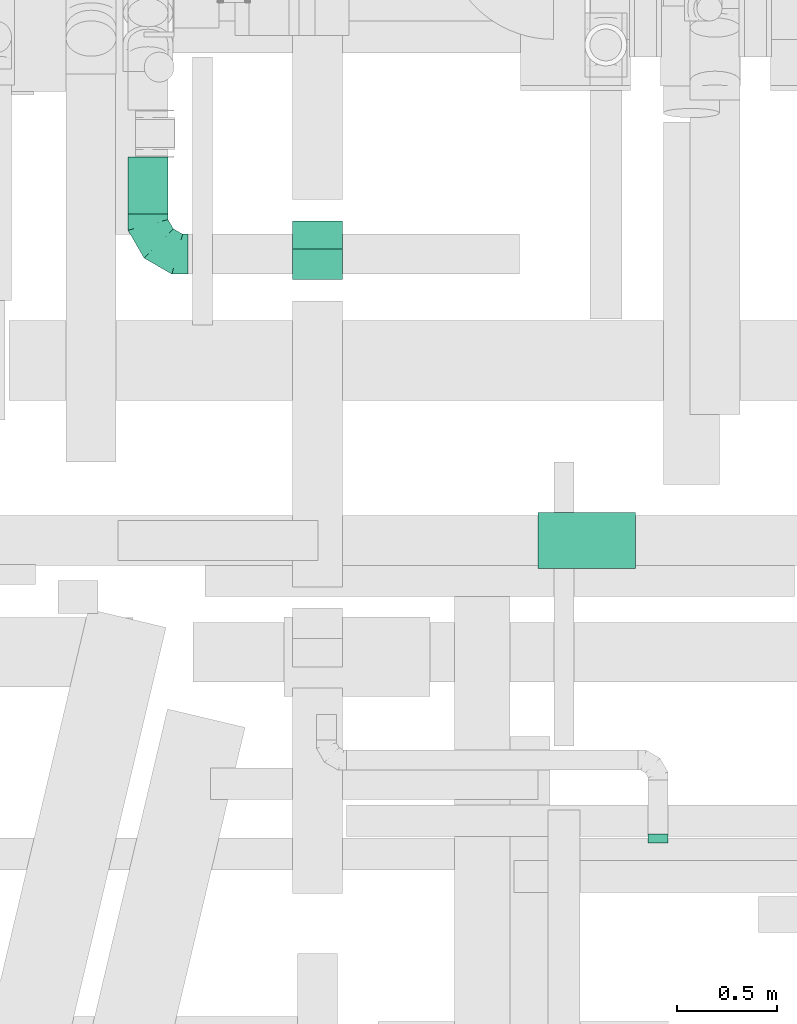
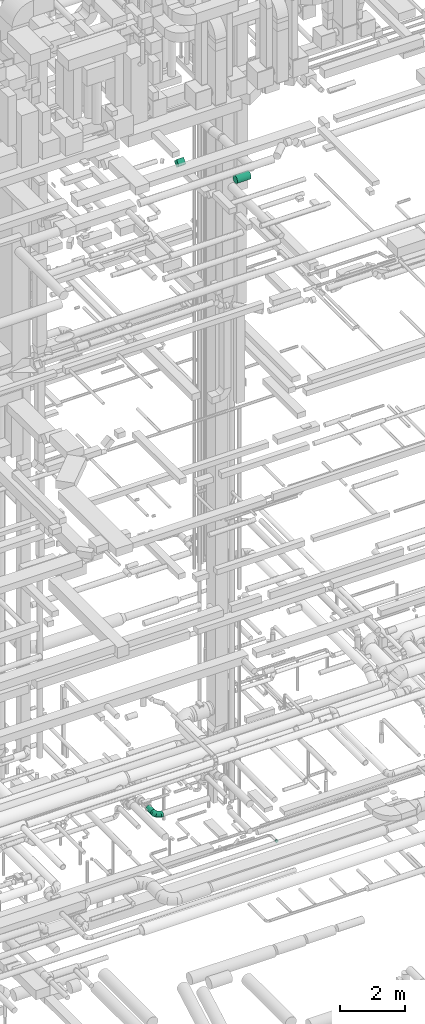
# One storey, part 208 of 337: 3 flow segments, 2 flow fittings.
"""IFC2X3 building model written with IfcOpenShell, lengths in millimetres."""

from ifc_helpers import new_model, entity, si_unit, converted_unit, derived_unit, direction, frame, origin, origin_2d_with_axis, place, context, subcontext, project, spatial, rectangle, circle, extrude, faceted_brep, source, transform, mapped, material, type_object, type_shapes, element, save


model = new_model("IFC2X3")

# Units and contexts
model_context = context("Model", 3, precision=0.01, world=origin(), true_north=direction((6.12303176911189e-17, 1.0)))
body_context = subcontext(model_context, "Body", "Model", "MODEL_VIEW")
ifc_project = project(units=[si_unit("LENGTHUNIT", "METRE", prefix="MILLI"), si_unit("AREAUNIT", "SQUARE_METRE"), si_unit("VOLUMEUNIT", "CUBIC_METRE"), converted_unit("PLANEANGLEUNIT", "DEGREE", entity("IfcRatioMeasure", 0.0174532925199433), si_unit("PLANEANGLEUNIT", "RADIAN"), dimensions=[0, 0, 0, 0, 0, 0, 0]), si_unit("MASSUNIT", "GRAM", prefix="KILO"), derived_unit("MASSDENSITYUNIT", [(si_unit("MASSUNIT", "GRAM", prefix="KILO"), 1), (si_unit("LENGTHUNIT", "METRE"), -3)]), derived_unit("MOMENTOFINERTIAUNIT", [(si_unit("LENGTHUNIT", "METRE"), 4)]), si_unit("TIMEUNIT", "SECOND"), si_unit("FREQUENCYUNIT", "HERTZ"), si_unit("THERMODYNAMICTEMPERATUREUNIT", "DEGREE_CELSIUS"), derived_unit("THERMALTRANSMITTANCEUNIT", [(si_unit("MASSUNIT", "GRAM", prefix="KILO"), 1), (si_unit("THERMODYNAMICTEMPERATUREUNIT", "KELVIN"), -1), (si_unit("TIMEUNIT", "SECOND"), -3)]), derived_unit("VOLUMETRICFLOWRATEUNIT", [(si_unit("LENGTHUNIT", "METRE"), 3), (si_unit("TIMEUNIT", "SECOND"), -1)]), derived_unit("MASSFLOWRATEUNIT", [(si_unit("MASSUNIT", "GRAM", prefix="KILO"), 1), (si_unit("TIMEUNIT", "SECOND"), -1)]), derived_unit("ROTATIONALFREQUENCYUNIT", [(si_unit("TIMEUNIT", "SECOND"), -1)]), si_unit("ELECTRICCURRENTUNIT", "AMPERE"), si_unit("ELECTRICVOLTAGEUNIT", "VOLT"), si_unit("POWERUNIT", "WATT"), si_unit("FORCEUNIT", "NEWTON", prefix="KILO"), si_unit("ILLUMINANCEUNIT", "LUX"), si_unit("LUMINOUSFLUXUNIT", "LUMEN"), si_unit("LUMINOUSINTENSITYUNIT", "CANDELA"), derived_unit("USERDEFINED", [(si_unit("MASSUNIT", "GRAM", prefix="KILO"), -1), (si_unit("LENGTHUNIT", "METRE"), -2), (si_unit("TIMEUNIT", "SECOND"), 3), (si_unit("LUMINOUSFLUXUNIT", "LUMEN"), 1)]), derived_unit("LINEARVELOCITYUNIT", [(si_unit("LENGTHUNIT", "METRE"), 1), (si_unit("TIMEUNIT", "SECOND"), -1)]), si_unit("PRESSUREUNIT", "PASCAL"), derived_unit("USERDEFINED", [(si_unit("LENGTHUNIT", "METRE"), -2), (si_unit("MASSUNIT", "GRAM", prefix="KILO"), 1), (si_unit("TIMEUNIT", "SECOND"), -2)]), derived_unit("LINEARFORCEUNIT", [(si_unit("MASSUNIT", "GRAM", prefix="KILO"), 1), (si_unit("LENGTHUNIT", "METRE"), 1), (si_unit("TIMEUNIT", "SECOND"), -2), (si_unit("LENGTHUNIT", "METRE"), -1)]), derived_unit("PLANARFORCEUNIT", [(si_unit("MASSUNIT", "GRAM", prefix="KILO"), 1), (si_unit("LENGTHUNIT", "METRE"), 1), (si_unit("TIMEUNIT", "SECOND"), -2), (si_unit("LENGTHUNIT", "METRE"), -2)])], contexts=[model_context])

# Site, building, storey
site_placement = place(None, origin())
site = spatial("IfcSite", under=ifc_project, at=site_placement, CompositionType="ELEMENT")
building_placement = place(site_placement, origin())
building = spatial("IfcBuilding", under=site, at=building_placement, CompositionType="ELEMENT")
storey_placement = place(building_placement, origin())
storey = spatial("IfcBuildingStorey", under=building, at=storey_placement, CompositionType="ELEMENT", Elevation=0.0)

# Flow segments
duct_segment_type_1 = type_object("IfcDuctSegmentType", PredefinedType="NOTDEFINED")
flow_segment_1_placement = place(storey_placement, frame((55054.59, 6985.29, 27252.51)))
element("IfcFlowSegment", 1, at=flow_segment_1_placement, inside=storey, type_object=duct_segment_type_1, context=body_context, shape_type="SweptSolid", body=[
    extrude(rectangle(XDim=217.157287525396, YDim=199.999999999996, at=origin_2d_with_axis()), frame((0.0, 147.49, 147.49), z_axis=(1.0, 0.0, 0.0), x_axis=(0.0, -0.707106781186548, -0.707106781186548)), (0.0, 0.0, 1.0), 249.999999999995),
])
duct_segment_type_2 = type_object("IfcDuctSegmentType", PredefinedType="NOTDEFINED")
flow_segment_2_placement = place(storey_placement, frame((54230.32, 7313.07, 3218.4)))
element("IfcFlowSegment", 2, at=flow_segment_2_placement, inside=storey, type_object=duct_segment_type_2, context=body_context, shape_type="SweptSolid", body=[
    extrude(circle(Radius=100.0, at=origin_2d_with_axis()), frame((101.6, 0.0, 101.6), z_axis=(0.0, 1.0, 0.0), x_axis=(-1.0, 0.0, 0.0)), (0.0, 0.0, 1.0), 285.608647646454),
])
flow_segment_3_placement = place(storey_placement, frame((56284.94, 5539.01, 27118.4)))
element("IfcFlowSegment", 3, at=flow_segment_3_placement, inside=storey, type_object=duct_segment_type_2, context=body_context, shape_type="SweptSolid", body=[
    extrude(circle(Radius=140.0, at=origin_2d_with_axis()), frame((0.0, 141.6, 141.6), z_axis=(1.0, 0.0, 0.0), x_axis=(0.0, -1.0, 0.0)), (0.0, 0.0, 1.0), 486.215898693762),
])

# Flow fittings
ifc_material = material()
duct_fitting_type_1 = type_object("IfcDuctFittingType", PredefinedType="NOTDEFINED", material=ifc_material)
shared_shape_1 = source(origin(), body_context, "Body", "Brep", [
    faceted_brep([(-200.0, 0.0, -100.0), (-200.0, -25.88, -96.59), (-200.0, -50.0, -86.6), (-200.0, -70.71, -70.71), (-200.0, -86.6, -50.0), (-200.0, -96.59, -25.88), (-200.0, -100.0, 0.0), (-200.0, -96.59, 25.88), (-200.0, -86.6, 50.0), (-200.0, -70.71, 70.71), (-200.0, -50.0, 86.6), (-200.0, -25.88, 96.59), (-200.0, 0.0, 100.0), (-200.0, 25.88, 96.59), (-200.0, 50.0, 86.6), (-200.0, 70.71, 70.71), (-200.0, 86.6, 50.0), (-200.0, 96.59, 25.88), (-200.0, 100.0, 0.0), (-200.0, 96.59, -25.88), (-200.0, 86.6, -50.0), (-200.0, 70.71, -70.71), (-200.0, 50.0, -86.6), (-200.0, 25.88, -96.59), (-153.35, 25.88, 96.59), (-159.81, 50.0, 86.6), (-146.41, 0.0, 100.0), (-165.36, 70.71, 70.71), (-172.29, 96.59, 25.88), (-173.21, 100.0, 0.0), (-169.62, 86.6, 50.0), (-169.62, 86.6, -50.0), (-165.36, 70.71, -70.71), (-172.29, 96.59, -25.88), (-153.35, 25.88, -96.59), (-146.41, 0.0, -100.0), (-159.81, 50.0, -86.6), (-139.48, -25.88, -96.59), (-133.01, -50.0, -86.6), (-127.46, -70.71, -70.71), (-123.21, -86.6, -50.0), (-120.53, -96.59, -25.88), (-119.62, -100.0, 0.0), (-120.53, -96.59, 25.88), (-123.21, -86.6, 50.0), (-127.46, -70.71, 70.71), (-133.01, -50.0, 86.6), (-139.48, -25.88, 96.59), (-72.54, 72.54, 96.59), (-90.19, 90.19, 86.6), (-53.59, 53.59, 100.0), (-105.35, 105.35, 70.71), (-116.99, 116.99, 50.0), (-124.3, 124.3, 25.88), (-126.79, 126.79, 0.0), (-124.3, 124.3, -25.88), (-116.99, 116.99, -50.0), (-105.35, 105.35, -70.71), (-72.54, 72.54, -96.59), (-53.59, 53.59, -100.0), (-90.19, 90.19, -86.6), (-34.64, 34.64, -96.59), (-16.99, 16.99, -86.6), (-1.83, 1.83, -70.71), (9.81, -9.81, -50.0), (17.12, -17.12, -25.88), (19.62, -19.62, 0.0), (17.12, -17.12, 25.88), (9.81, -9.81, 50.0), (-1.83, 1.83, 70.71), (-16.99, 16.99, 86.6), (-34.64, 34.64, 96.59), (-25.88, 153.35, 96.59), (-50.0, 159.81, 86.6), (0.0, 146.41, 100.0), (-70.71, 165.36, 70.71), (-86.6, 169.62, 50.0), (-96.59, 172.29, 25.88), (-100.0, 173.21, 0.0), (-96.59, 172.29, -25.88), (-86.6, 169.62, -50.0), (-70.71, 165.36, -70.71), (-25.88, 153.35, -96.59), (0.0, 146.41, -100.0), (-50.0, 159.81, -86.6), (25.88, 139.48, -96.59), (50.0, 133.01, -86.6), (70.71, 127.46, -70.71), (86.6, 123.21, -50.0), (96.59, 120.53, -25.88), (100.0, 119.62, 0.0), (96.59, 120.53, 25.88), (86.6, 123.21, 50.0), (70.71, 127.46, 70.71), (50.0, 133.01, 86.6), (25.88, 139.48, 96.59), (-25.88, 200.0, -96.59), (-50.0, 200.0, -86.6), (-70.71, 200.0, -70.71), (-86.6, 200.0, -50.0), (-96.59, 200.0, -25.88), (-100.0, 200.0, 0.0), (-96.59, 200.0, 25.88), (-86.6, 200.0, 50.0), (-70.71, 200.0, 70.71), (-50.0, 200.0, 86.6), (-25.88, 200.0, 96.59), (0.0, 200.0, 100.0), (25.88, 200.0, 96.59), (50.0, 200.0, 86.6), (70.71, 200.0, 70.71), (86.6, 200.0, 50.0), (96.59, 200.0, 25.88), (100.0, 200.0, 0.0), (96.59, 200.0, -25.88), (86.6, 200.0, -50.0), (70.71, 200.0, -70.71), (50.0, 200.0, -86.6), (25.88, 200.0, -96.59), (0.0, 200.0, -100.0)], [[[0, 1, 2, 3, 4, 5, 6, 7, 8, 9, 10, 11, 12, 13, 14, 15, 16, 17, 18, 19, 20, 21, 22, 23]], [[24, 25, 14, 13]], [[26, 24, 13, 12]], [[14, 25, 27, 15]], [[28, 29, 18, 17]], [[30, 28, 17, 16]], [[15, 27, 30, 16]], [[20, 31, 32, 21]], [[33, 31, 20, 19]], [[18, 29, 33, 19]], [[34, 35, 0, 23]], [[36, 34, 23, 22]], [[32, 36, 22, 21]], [[1, 0, 35, 37]], [[2, 1, 37, 38]], [[38, 39, 3, 2]], [[5, 4, 40, 41]], [[6, 5, 41, 42]], [[39, 40, 4, 3]], [[6, 42, 43, 7]], [[7, 43, 44, 8]], [[8, 44, 45, 9]], [[9, 45, 46, 10]], [[10, 46, 47, 11]], [[26, 12, 11, 47]], [[48, 49, 25, 24]], [[50, 48, 24, 26]], [[27, 25, 49, 51]], [[52, 53, 28, 30]], [[51, 52, 30, 27]], [[29, 28, 53, 54]], [[55, 56, 31, 33]], [[54, 55, 33, 29]], [[32, 31, 56, 57]], [[58, 59, 35, 34]], [[60, 58, 34, 36]], [[57, 60, 36, 32]], [[37, 35, 59, 61]], [[38, 37, 61, 62]], [[39, 38, 62, 63]], [[41, 40, 64, 65]], [[42, 41, 65, 66]], [[63, 64, 40, 39]], [[43, 42, 66, 67]], [[44, 43, 67, 68]], [[68, 69, 45, 44]], [[46, 45, 69, 70]], [[47, 46, 70, 71]], [[26, 47, 71, 50]], [[72, 73, 49, 48]], [[74, 72, 48, 50]], [[51, 49, 73, 75]], [[76, 77, 53, 52]], [[75, 76, 52, 51]], [[54, 53, 77, 78]], [[79, 80, 56, 55]], [[78, 79, 55, 54]], [[57, 56, 80, 81]], [[82, 83, 59, 58]], [[84, 82, 58, 60]], [[81, 84, 60, 57]], [[61, 59, 83, 85]], [[62, 61, 85, 86]], [[63, 62, 86, 87]], [[65, 64, 88, 89]], [[66, 65, 89, 90]], [[87, 88, 64, 63]], [[67, 66, 90, 91]], [[68, 67, 91, 92]], [[92, 93, 69, 68]], [[70, 69, 93, 94]], [[71, 70, 94, 95]], [[50, 71, 95, 74]], [[96, 97, 98, 99, 100, 101, 102, 103, 104, 105, 106, 107, 108, 109, 110, 111, 112, 113, 114, 115, 116, 117, 118, 119]], [[72, 74, 107, 106]], [[73, 72, 106, 105]], [[75, 73, 105, 104]], [[102, 101, 78, 77]], [[103, 102, 77, 76]], [[75, 104, 103, 76]], [[78, 101, 100, 79]], [[79, 100, 99, 80]], [[80, 99, 98, 81]], [[84, 97, 96, 82]], [[82, 96, 119, 83]], [[84, 81, 98, 97]], [[118, 117, 86, 85]], [[119, 118, 85, 83]], [[116, 87, 86, 117]], [[88, 115, 114, 89]], [[89, 114, 113, 90]], [[115, 88, 87, 116]], [[91, 90, 113, 112]], [[92, 91, 112, 111]], [[111, 110, 93, 92]], [[95, 94, 109, 108]], [[74, 95, 108, 107]], [[110, 109, 94, 93]]]),
])
type_shapes(duct_fitting_type_1, [shared_shape_1])
flow_fitting_1_placement = place(storey_placement, frame((54331.91, 7113.07, 3320.0), z_axis=(0.0, 0.0, 1.0), x_axis=(0.0, -1.0, 0.0)))
element("IfcFlowFitting", 4, at=flow_fitting_1_placement, inside=storey, type_object=duct_fitting_type_1, material=ifc_material, context=body_context, shape_type="MappedRepresentation", body=[
    mapped(shared_shape_1, transform((0.0, 0.0, 0.0), scale=1.0)),
])
duct_fitting_type_2 = type_object("IfcDuctFittingType", PredefinedType="NOTDEFINED", material=ifc_material)
shared_shape_2 = source(origin(), body_context, "Body", "Brep", [
    faceted_brep([(20.0, 12.94, -48.3), (20.0, 25.0, -43.3), (20.0, 35.36, -35.36), (20.0, 43.3, -25.0), (20.0, 48.3, -12.94), (20.0, 50.0, 0.0), (20.0, 48.3, 12.94), (20.0, 43.3, 25.0), (20.0, 35.36, 35.36), (20.0, 25.0, 43.3), (20.0, 12.94, 48.3), (20.0, 0.0, 50.0), (20.0, -12.94, 48.3), (20.0, -25.0, 43.3), (20.0, -35.36, 35.36), (20.0, -43.3, 25.0), (20.0, -48.3, 12.94), (20.0, -50.0, 0.0), (20.0, -48.3, -12.94), (20.0, -43.3, -25.0), (20.0, -35.36, -35.36), (20.0, -25.0, -43.3), (20.0, -12.94, -48.3), (20.0, 0.0, -50.0), (0.0, 0.0, 50.0), (0.0, 12.94, 48.3), (-23.65, 12.94, 48.3), (-23.65, 0.0, 50.0), (0.0, 25.0, 43.3), (-23.65, 25.0, 43.3), (0.0, 35.36, 35.36), (-23.65, 35.36, 35.36), (0.0, 43.3, 25.0), (0.0, 48.3, 12.94), (-23.65, 48.3, 12.94), (-23.65, 43.3, 25.0), (0.0, 50.0, 0.0), (-23.65, 50.0, 0.0), (0.0, 48.3, -12.94), (-23.65, 48.3, -12.94), (0.0, 43.3, -25.0), (-23.65, 43.3, -25.0), (0.0, 35.36, -35.36), (-23.65, 35.36, -35.36), (0.0, 25.0, -43.3), (0.0, 12.94, -48.3), (-23.65, 12.94, -48.3), (-23.65, 25.0, -43.3), (0.0, 0.0, -50.0), (-23.65, 0.0, -50.0), (0.0, -12.94, -48.3), (-23.65, -12.94, -48.3), (0.0, -25.0, -43.3), (-23.65, -25.0, -43.3), (0.0, -35.36, -35.36), (-23.65, -35.36, -35.36), (0.0, -43.3, -25.0), (0.0, -48.3, -12.94), (-23.65, -48.3, -12.94), (-23.65, -43.3, -25.0), (0.0, -50.0, 0.0), (-23.65, -50.0, 0.0), (0.0, -48.3, 12.94), (-23.65, -48.3, 12.94), (0.0, -43.3, 25.0), (-23.65, -43.3, 25.0), (0.0, -35.36, 35.36), (-23.65, -35.36, 35.36), (0.0, -25.0, 43.3), (0.0, -12.94, 48.3), (-23.65, -12.94, 48.3), (-23.65, -25.0, 43.3)], [[[0, 1, 2, 3, 4, 5, 6, 7, 8, 9, 10, 11, 12, 13, 14, 15, 16, 17, 18, 19, 20, 21, 22, 23]], [[24, 11, 10, 25, 26, 27]], [[25, 10, 9, 28, 29, 26]], [[28, 9, 8, 30, 31, 29]], [[32, 7, 6, 33, 34, 35]], [[33, 6, 5, 36, 37, 34]], [[30, 8, 7, 32, 35, 31]], [[36, 5, 4, 38, 39, 37]], [[38, 4, 3, 40, 41, 39]], [[40, 3, 2, 42, 43, 41]], [[44, 1, 0, 45, 46, 47]], [[45, 0, 23, 48, 49, 46]], [[42, 2, 1, 44, 47, 43]], [[48, 23, 22, 50, 51, 49]], [[50, 22, 21, 52, 53, 51]], [[52, 21, 20, 54, 55, 53]], [[56, 19, 18, 57, 58, 59]], [[57, 18, 17, 60, 61, 58]], [[54, 20, 19, 56, 59, 55]], [[60, 17, 16, 62, 63, 61]], [[62, 16, 15, 64, 65, 63]], [[64, 15, 14, 66, 67, 65]], [[68, 13, 12, 69, 70, 71]], [[69, 12, 11, 24, 27, 70]], [[66, 14, 13, 68, 71, 67]], [[49, 51, 53, 55, 59, 58, 61, 63, 65, 67, 71, 70, 27, 26, 29, 31, 35, 34, 37, 39, 41, 43, 47, 46]]]),
])
type_shapes(duct_fitting_type_2, [shared_shape_2])
flow_fitting_2_placement = place(storey_placement, frame((56885.06, 4190.29, 3250.0), z_axis=(0.0, 0.0, -1.0), x_axis=(0.0, 1.0, 0.0)))
element("IfcFlowFitting", 5, at=flow_fitting_2_placement, inside=storey, type_object=duct_fitting_type_2, material=ifc_material, context=body_context, shape_type="MappedRepresentation", body=[
    mapped(shared_shape_2, transform((0.0, 0.0, 0.0), scale=1.0)),
])

save(model, "model.ifc")
